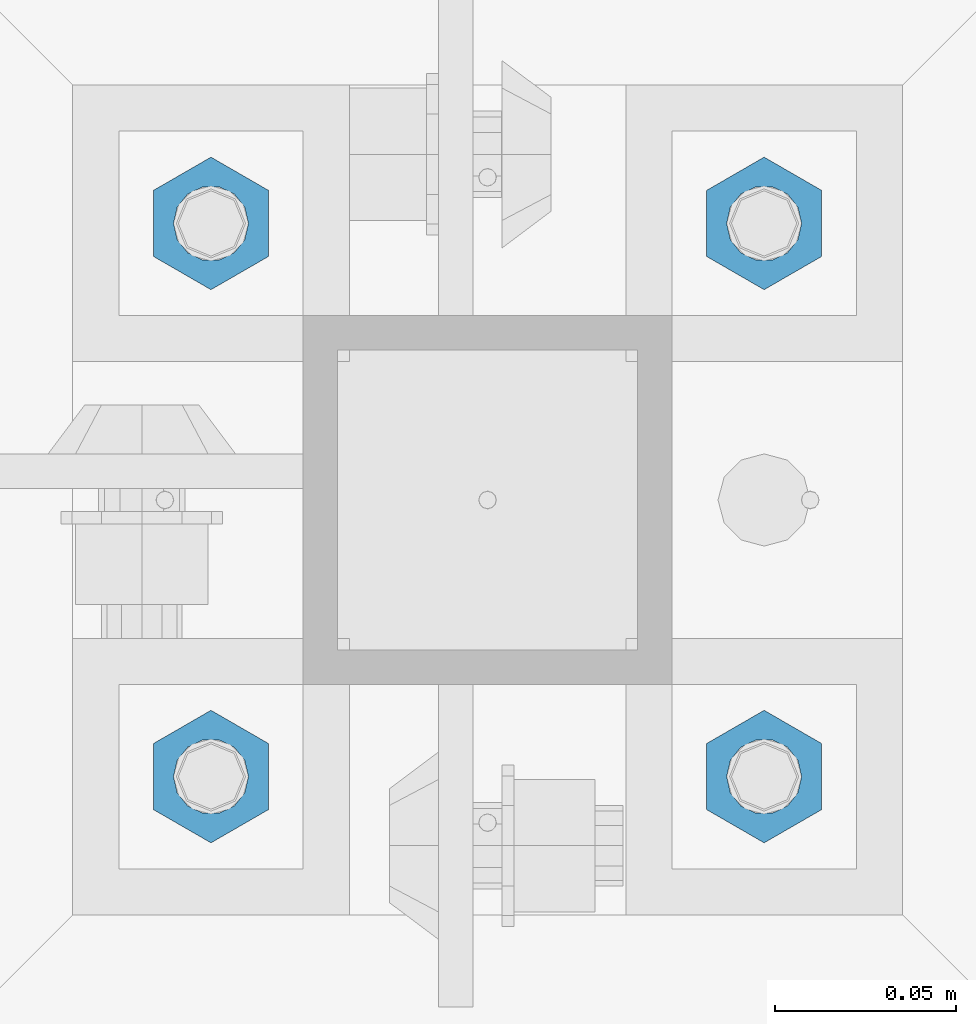
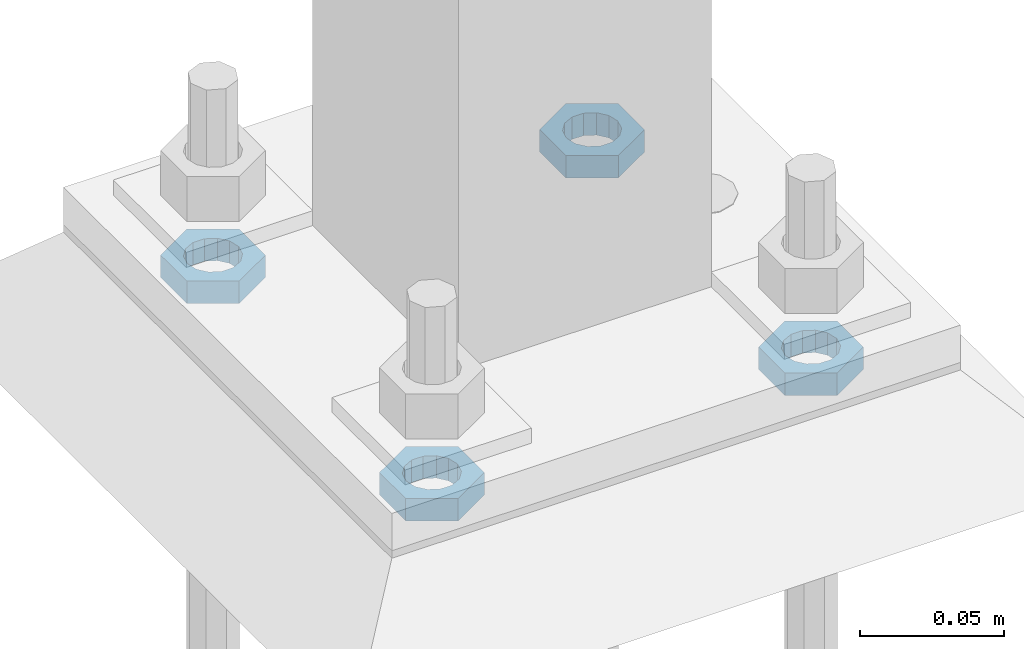
# One storey, part 2849 of 3843: 4 beams, 1 element without a shape of its own.
"""IFC2X3 building model written with IfcOpenShell, lengths in millimetres."""

from ifc_helpers import new_model, si_unit, frame, origin_with_axes, place, context, subcontext, project, spatial, faceted_brep, material, type_object, element, aggregate, save


model = new_model("IFC2X3")

# Units and contexts
model_context = context("Model", 3, precision=1e-05, world=origin_with_axes())
body_context = subcontext(model_context, "Body", "Model", "MODEL_VIEW")
ifc_project = project(units=[si_unit("LENGTHUNIT", "METRE", prefix="MILLI"), si_unit("AREAUNIT", "SQUARE_METRE"), si_unit("VOLUMEUNIT", "CUBIC_METRE"), si_unit("MASSUNIT", "GRAM", prefix="KILO"), si_unit("TIMEUNIT", "SECOND"), si_unit("PLANEANGLEUNIT", "RADIAN"), si_unit("SOLIDANGLEUNIT", "STERADIAN"), si_unit("THERMODYNAMICTEMPERATUREUNIT", "DEGREE_CELSIUS"), si_unit("LUMINOUSINTENSITYUNIT", "LUMEN")], contexts=[model_context])

# Site, building, storey
site_placement = place(None, origin_with_axes())
site = spatial("IfcSite", under=ifc_project, at=site_placement, CompositionType="ELEMENT")
building_placement = place(site_placement, origin_with_axes())
building = spatial("IfcBuilding", under=site, at=building_placement, Name="Undefined", CompositionType="ELEMENT")
storey_placement = place(building_placement, origin_with_axes())
storey = spatial("IfcBuildingStorey", under=building, at=storey_placement, Name="Undefined", CompositionType="ELEMENT", Elevation=0.0)

# Assembly, beams
assembly_placement = place(storey_placement, origin_with_axes())
assembly = element("IfcElementAssembly", 1, at=assembly_placement, inside=storey, Name="TEMPLATE", AssemblyPlace="NOTDEFINED", PredefinedType="RIGID_FRAME")
ifc_material = material(Name="STEEL/A572-50")
beam_type = type_object("IfcBeamType", Name="3/4_HALF_NUT", PredefinedType="NOTDEFINED")
beam_1_placement = place(assembly_placement, frame((38744.525, 50482.5, 30060.9), z_axis=(1.0, 0.0, 0.0), x_axis=(0.0, 0.0, -1.0)))
beam_1 = element("IfcBeam", 2, at=beam_1_placement, type_object=beam_type, material=ifc_material, Name="NUT", ObjectType="3/4_HALF_NUT", context=body_context, shape_type="Brep", body=[
    faceted_brep([(0.0, -18.2600002288818, 0.0), (0.0, -9.13000011444092, -15.8100004196167), (9.52500000000146, -9.13000011444092, -15.8100004196167), (9.52500000000146, -18.2600002288818, 0.0), (0.0, 9.13000011444092, -15.8100004196167), (9.52500000000146, 9.13000011444092, -15.8100004196167), (0.0, 18.2600002288818, 0.0), (9.52500000000146, 18.2600002288818, 0.0), (0.0, 9.13000011444092, 15.8100004196167), (9.52500000000146, 9.13000011444092, 15.8100004196167), (0.0, -9.13000011444092, 15.8100004196167), (9.52500000000146, -9.13000011444092, 15.8100004196167), (0.0, 0.0, 10.3199996948242), (0.0, 4.47768005527905, 9.29799844179797), (9.52500000000146, 4.47768005527905, 9.29799844179797), (9.52500000000146, 0.0, 10.3199996948242), (0.0, 8.06850066047627, 6.43441456490837), (9.52500000000146, 8.06850066047627, 6.43441456490837), (0.0, 10.0612557561908, 2.2964159705225), (9.52500000000146, 10.0612557561908, 2.2964159705225), (0.0, 10.0612557561908, -2.2964159705225), (9.52500000000146, 10.0612557561908, -2.2964159705225), (0.0, 8.06850066047627, -6.43441456490837), (9.52500000000146, 8.06850066047627, -6.43441456490837), (0.0, 4.47768005527905, -9.29799844179797), (9.52500000000146, 4.47768005527905, -9.29799844179797), (0.0, 0.0, -10.3199996948242), (9.52500000000146, 0.0, -10.3199996948242), (0.0, -4.47768005527905, -9.29799844179797), (9.52500000000146, -4.47768005527905, -9.29799844179797), (0.0, -8.06850066047627, -6.43441456490837), (9.52500000000146, -8.06850066047627, -6.43441456490837), (0.0, -10.0612557561908, -2.2964159705225), (9.52500000000146, -10.0612557561908, -2.2964159705225), (0.0, -10.0612557561908, 2.2964159705225), (9.52500000000146, -10.0612557561908, 2.2964159705225), (0.0, -8.06850066047627, 6.43441456490837), (9.52500000000146, -8.06850066047627, 6.43441456490837), (0.0, -4.47768005527905, 9.29799844179797), (9.52500000000146, -4.47768005527905, 9.29799844179797)], [[[0, 1, 2, 3]], [[1, 4, 5, 2]], [[4, 6, 7, 5]], [[6, 8, 9, 7]], [[8, 10, 11, 9]], [[10, 0, 3, 11]], [[12, 13, 14, 15]], [[13, 16, 17, 14]], [[16, 18, 19, 17]], [[18, 20, 21, 19]], [[20, 22, 23, 21]], [[22, 24, 25, 23]], [[24, 26, 27, 25]], [[26, 28, 29, 27]], [[28, 30, 31, 29]], [[30, 32, 33, 31]], [[32, 34, 35, 33]], [[34, 36, 37, 35]], [[36, 38, 39, 37]], [[38, 12, 15, 39]], [[5, 7, 9, 11, 3, 2], [17, 19, 21, 23, 25, 27, 29, 31, 33, 35, 37, 39, 15, 14]], [[10, 8, 6, 4, 1, 0], [38, 36, 34, 32, 30, 28, 26, 24, 22, 20, 18, 16, 13, 12]]]),
])
beam_2_placement = place(assembly_placement, frame((38744.525, 50634.9, 30060.9), z_axis=(-1.0, 0.0, 0.0), x_axis=(0.0, 0.0, -1.0)))
beam_2 = element("IfcBeam", 3, at=beam_2_placement, type_object=beam_type, material=ifc_material, Name="NUT", ObjectType="3/4_HALF_NUT", context=body_context, shape_type="Brep", body=[
    faceted_brep([(0.0, -18.2600002288818, 0.0), (0.0, -9.13000011444092, -15.8100004196167), (9.52500000000146, -9.13000011444092, -15.8100004196167), (9.52500000000146, -18.2600002288818, 0.0), (0.0, 9.13000011444092, -15.8100004196167), (9.52500000000146, 9.13000011444092, -15.8100004196167), (0.0, 18.2600002288818, 0.0), (9.52500000000146, 18.2600002288818, 0.0), (0.0, 9.13000011444092, 15.8100004196167), (9.52500000000146, 9.13000011444092, 15.8100004196167), (0.0, -9.13000011444092, 15.8100004196167), (9.52500000000146, -9.13000011444092, 15.8100004196167), (0.0, 0.0, 10.3199996948242), (0.0, 4.47768005527905, 9.29799844179797), (9.52500000000146, 4.47768005527905, 9.29799844179797), (9.52500000000146, 0.0, 10.3199996948242), (0.0, 8.06850066047627, 6.43441456490837), (9.52500000000146, 8.06850066047627, 6.43441456490837), (0.0, 10.0612557561908, 2.2964159705225), (9.52500000000146, 10.0612557561908, 2.2964159705225), (0.0, 10.0612557561908, -2.2964159705225), (9.52500000000146, 10.0612557561908, -2.2964159705225), (0.0, 8.06850066047627, -6.43441456490837), (9.52500000000146, 8.06850066047627, -6.43441456490837), (0.0, 4.47768005527905, -9.29799844179797), (9.52500000000146, 4.47768005527905, -9.29799844179797), (0.0, 0.0, -10.3199996948242), (9.52500000000146, 0.0, -10.3199996948242), (0.0, -4.47768005527905, -9.29799844179797), (9.52500000000146, -4.47768005527905, -9.29799844179797), (0.0, -8.06850066047627, -6.43441456490837), (9.52500000000146, -8.06850066047627, -6.43441456490837), (0.0, -10.0612557561908, -2.2964159705225), (9.52500000000146, -10.0612557561908, -2.2964159705225), (0.0, -10.0612557561908, 2.2964159705225), (9.52500000000146, -10.0612557561908, 2.2964159705225), (0.0, -8.06850066047627, 6.43441456490837), (9.52500000000146, -8.06850066047627, 6.43441456490837), (0.0, -4.47768005527905, 9.29799844179797), (9.52500000000146, -4.47768005527905, 9.29799844179797)], [[[0, 1, 2, 3]], [[1, 4, 5, 2]], [[4, 6, 7, 5]], [[6, 8, 9, 7]], [[8, 10, 11, 9]], [[10, 0, 3, 11]], [[12, 13, 14, 15]], [[13, 16, 17, 14]], [[16, 18, 19, 17]], [[18, 20, 21, 19]], [[20, 22, 23, 21]], [[22, 24, 25, 23]], [[24, 26, 27, 25]], [[26, 28, 29, 27]], [[28, 30, 31, 29]], [[30, 32, 33, 31]], [[32, 34, 35, 33]], [[34, 36, 37, 35]], [[36, 38, 39, 37]], [[38, 12, 15, 39]], [[5, 7, 9, 11, 3, 2], [17, 19, 21, 23, 25, 27, 29, 31, 33, 35, 37, 39, 15, 14]], [[10, 8, 6, 4, 1, 0], [38, 36, 34, 32, 30, 28, 26, 24, 22, 20, 18, 16, 13, 12]]]),
])
beam_3_placement = place(assembly_placement, frame((38896.925, 50634.9, 30060.9), z_axis=(-1.0, 0.0, 0.0), x_axis=(0.0, 0.0, -1.0)))
beam_3 = element("IfcBeam", 4, at=beam_3_placement, type_object=beam_type, material=ifc_material, Name="NUT", ObjectType="3/4_HALF_NUT", context=body_context, shape_type="Brep", body=[
    faceted_brep([(0.0, -18.2600002288818, 0.0), (0.0, -9.13000011444092, -15.8100004196167), (9.52500000000146, -9.13000011444092, -15.8100004196167), (9.52500000000146, -18.2600002288818, 0.0), (0.0, 9.13000011444092, -15.8100004196167), (9.52500000000146, 9.13000011444092, -15.8100004196167), (0.0, 18.2600002288818, 0.0), (9.52500000000146, 18.2600002288818, 0.0), (0.0, 9.13000011444092, 15.8100004196167), (9.52500000000146, 9.13000011444092, 15.8100004196167), (0.0, -9.13000011444092, 15.8100004196167), (9.52500000000146, -9.13000011444092, 15.8100004196167), (0.0, 0.0, 10.3199996948242), (0.0, 4.47768005527905, 9.29799844179797), (9.52500000000146, 4.47768005527905, 9.29799844179797), (9.52500000000146, 0.0, 10.3199996948242), (0.0, 8.06850066047627, 6.43441456490837), (9.52500000000146, 8.06850066047627, 6.43441456490837), (0.0, 10.0612557561908, 2.2964159705225), (9.52500000000146, 10.0612557561908, 2.2964159705225), (0.0, 10.0612557561908, -2.2964159705225), (9.52500000000146, 10.0612557561908, -2.2964159705225), (0.0, 8.06850066047627, -6.43441456490837), (9.52500000000146, 8.06850066047627, -6.43441456490837), (0.0, 4.47768005527905, -9.29799844179797), (9.52500000000146, 4.47768005527905, -9.29799844179797), (0.0, 0.0, -10.3199996948242), (9.52500000000146, 0.0, -10.3199996948242), (0.0, -4.47768005527905, -9.29799844179797), (9.52500000000146, -4.47768005527905, -9.29799844179797), (0.0, -8.06850066047627, -6.43441456490837), (9.52500000000146, -8.06850066047627, -6.43441456490837), (0.0, -10.0612557561908, -2.2964159705225), (9.52500000000146, -10.0612557561908, -2.2964159705225), (0.0, -10.0612557561908, 2.2964159705225), (9.52500000000146, -10.0612557561908, 2.2964159705225), (0.0, -8.06850066047627, 6.43441456490837), (9.52500000000146, -8.06850066047627, 6.43441456490837), (0.0, -4.47768005527905, 9.29799844179797), (9.52500000000146, -4.47768005527905, 9.29799844179797)], [[[0, 1, 2, 3]], [[1, 4, 5, 2]], [[4, 6, 7, 5]], [[6, 8, 9, 7]], [[8, 10, 11, 9]], [[10, 0, 3, 11]], [[12, 13, 14, 15]], [[13, 16, 17, 14]], [[16, 18, 19, 17]], [[18, 20, 21, 19]], [[20, 22, 23, 21]], [[22, 24, 25, 23]], [[24, 26, 27, 25]], [[26, 28, 29, 27]], [[28, 30, 31, 29]], [[30, 32, 33, 31]], [[32, 34, 35, 33]], [[34, 36, 37, 35]], [[36, 38, 39, 37]], [[38, 12, 15, 39]], [[5, 7, 9, 11, 3, 2], [17, 19, 21, 23, 25, 27, 29, 31, 33, 35, 37, 39, 15, 14]], [[10, 8, 6, 4, 1, 0], [38, 36, 34, 32, 30, 28, 26, 24, 22, 20, 18, 16, 13, 12]]]),
])
beam_4_placement = place(assembly_placement, frame((38896.925, 50482.5, 30060.9), z_axis=(1.0, 0.0, 0.0), x_axis=(0.0, 0.0, -1.0)))
beam_4 = element("IfcBeam", 5, at=beam_4_placement, type_object=beam_type, material=ifc_material, Name="NUT", ObjectType="3/4_HALF_NUT", context=body_context, shape_type="Brep", body=[
    faceted_brep([(0.0, -18.2600002288818, 0.0), (0.0, -9.13000011444092, -15.8100004196167), (9.52500000000146, -9.13000011444092, -15.8100004196167), (9.52500000000146, -18.2600002288818, 0.0), (0.0, 9.13000011444092, -15.8100004196167), (9.52500000000146, 9.13000011444092, -15.8100004196167), (0.0, 18.2600002288818, 0.0), (9.52500000000146, 18.2600002288818, 0.0), (0.0, 9.13000011444092, 15.8100004196167), (9.52500000000146, 9.13000011444092, 15.8100004196167), (0.0, -9.13000011444092, 15.8100004196167), (9.52500000000146, -9.13000011444092, 15.8100004196167), (0.0, 0.0, 10.3199996948242), (0.0, 4.47768005527905, 9.29799844179797), (9.52500000000146, 4.47768005527905, 9.29799844179797), (9.52500000000146, 0.0, 10.3199996948242), (0.0, 8.06850066047627, 6.43441456490837), (9.52500000000146, 8.06850066047627, 6.43441456490837), (0.0, 10.0612557561908, 2.2964159705225), (9.52500000000146, 10.0612557561908, 2.2964159705225), (0.0, 10.0612557561908, -2.2964159705225), (9.52500000000146, 10.0612557561908, -2.2964159705225), (0.0, 8.06850066047627, -6.43441456490837), (9.52500000000146, 8.06850066047627, -6.43441456490837), (0.0, 4.47768005527905, -9.29799844179797), (9.52500000000146, 4.47768005527905, -9.29799844179797), (0.0, 0.0, -10.3199996948242), (9.52500000000146, 0.0, -10.3199996948242), (0.0, -4.47768005527905, -9.29799844179797), (9.52500000000146, -4.47768005527905, -9.29799844179797), (0.0, -8.06850066047627, -6.43441456490837), (9.52500000000146, -8.06850066047627, -6.43441456490837), (0.0, -10.0612557561908, -2.2964159705225), (9.52500000000146, -10.0612557561908, -2.2964159705225), (0.0, -10.0612557561908, 2.2964159705225), (9.52500000000146, -10.0612557561908, 2.2964159705225), (0.0, -8.06850066047627, 6.43441456490837), (9.52500000000146, -8.06850066047627, 6.43441456490837), (0.0, -4.47768005527905, 9.29799844179797), (9.52500000000146, -4.47768005527905, 9.29799844179797)], [[[0, 1, 2, 3]], [[1, 4, 5, 2]], [[4, 6, 7, 5]], [[6, 8, 9, 7]], [[8, 10, 11, 9]], [[10, 0, 3, 11]], [[12, 13, 14, 15]], [[13, 16, 17, 14]], [[16, 18, 19, 17]], [[18, 20, 21, 19]], [[20, 22, 23, 21]], [[22, 24, 25, 23]], [[24, 26, 27, 25]], [[26, 28, 29, 27]], [[28, 30, 31, 29]], [[30, 32, 33, 31]], [[32, 34, 35, 33]], [[34, 36, 37, 35]], [[36, 38, 39, 37]], [[38, 12, 15, 39]], [[5, 7, 9, 11, 3, 2], [17, 19, 21, 23, 25, 27, 29, 31, 33, 35, 37, 39, 15, 14]], [[10, 8, 6, 4, 1, 0], [38, 36, 34, 32, 30, 28, 26, 24, 22, 20, 18, 16, 13, 12]]]),
])
aggregate(assembly, [beam_1, beam_2, beam_3, beam_4])

save(model, "model.ifc")
